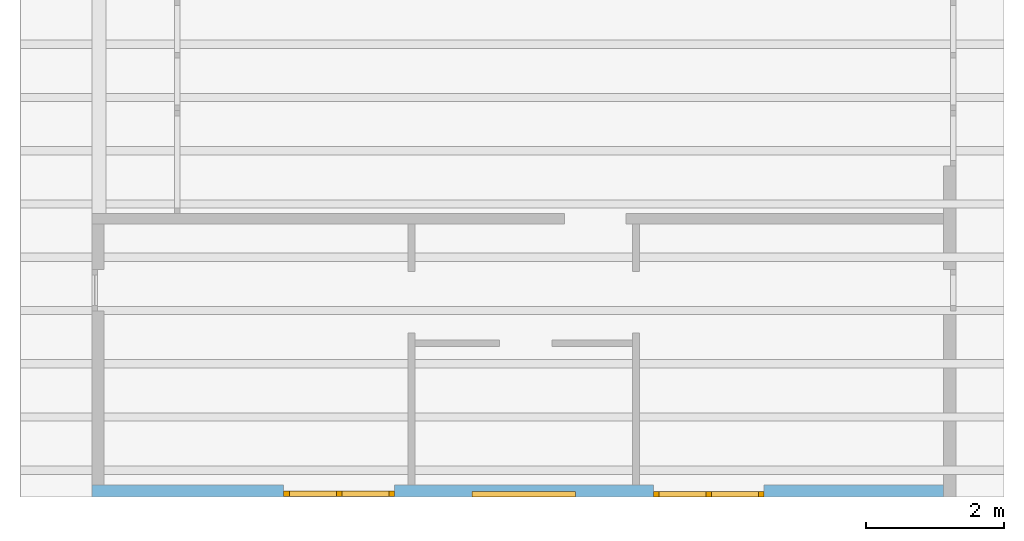
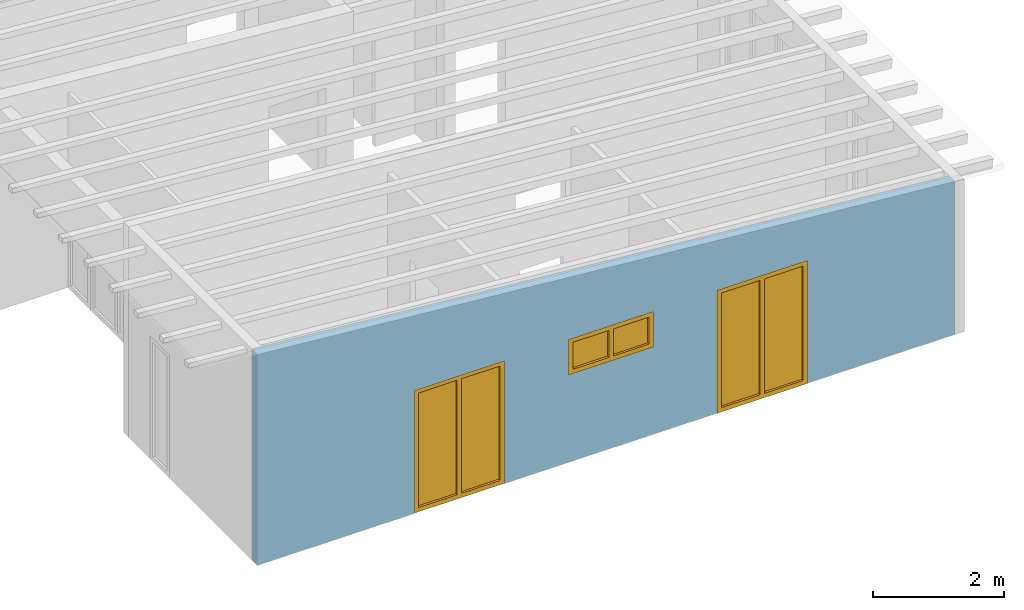
# One storey, part 5 of 13: 3 windows, 3 openings, plus 1 element that does not belong to this part.
"""IFC2X3 building model written with IfcOpenShell, lengths in millimetres."""

from ifc_helpers import new_model, entity, si_unit, converted_unit, frame, frame_2d, origin, origin_with_axes, place, context, project, spatial, rectangle, extrude, clip, halfspace, faceted_brep, material, layer, layer_set, layer_usage, element, fill, save


model = new_model("IFC2X3")

# Units and contexts
model_context = context("Model", 3, precision=1e-05, world=origin())
plan_context = context("Plan", 3, precision=1e-05, world=origin())
ifc_project = project(units=[si_unit("LENGTHUNIT", "METRE", prefix="MILLI"), converted_unit("PLANEANGLEUNIT", "DEGREE", entity("IfcPlaneAngleMeasure", 0.0174532925199433), si_unit("PLANEANGLEUNIT", "RADIAN"), dimensions=[0, 0, 0, 0, 0, 0, 0]), si_unit("AREAUNIT", "SQUARE_METRE"), si_unit("VOLUMEUNIT", "CUBIC_METRE")], contexts=[model_context, plan_context])

# Building, storey
building_placement = place(None, origin())
building = spatial("IfcBuilding", under=ifc_project, at=building_placement, CompositionType="ELEMENT")
storey_placement = place(building_placement, frame((0.0, 0.0, 4770.0), z_axis=(0.0, 0.0, 1.0), x_axis=(1.0, 0.0, 0.0)))
storey = spatial("IfcBuildingStorey", under=building, at=storey_placement, Name="Geschoss", CompositionType="ELEMENT", Elevation=4770.0)

# Wall, openings, windows
ifc_material_1 = material()
ifc_layer = layer(ifc_material_1, 175.0)
ifc_layer_set = layer_set([ifc_layer])
ifc_layer_usage = layer_usage(ifc_layer_set, "AXIS2", "POSITIVE", 0.0)
wall_placement = place(storey_placement, frame((21188.3517822139, -8691.5625, 0.0), z_axis=(0.0, 0.0, 1.0), x_axis=(1.0, 0.0, 0.0)))
wall = element("IfcWallStandardCase", 1, at=wall_placement, inside=storey, material=ifc_layer_usage, context=model_context, shape_type="Clipping", body=[
    clip(extrude(rectangle(XDim=12324.9999999553, YDim=175.0, at=frame_2d((6162.49999997765, 87.5), x_axis=(1.0, 0.0))), origin_with_axes(), (0.0, 0.0, 1.0), 3940.60829407405), halfspace(frame((12324.9999999553, 175.0, 2862.31051612095), z_axis=(-0.0871557427476578, 0.0, -0.996194698091746), x_axis=(1.0, 0.0, 0.0)), True)),
])
opening_1_placement = place(wall_placement, frame((8124.9982195274, 0.0, 0.0), z_axis=(0.0, 1.0, 0.0), x_axis=(0.0, 0.0, 1.0)))
opening_1 = element("IfcOpeningElement", 2, at=opening_1_placement, cuts=wall, ObjectType="Opening", context=model_context, shape_type="SweptSolid", body=[
    extrude(rectangle(XDim=2300.0, YDim=1600.0, at=frame_2d((1150.0, 800.0), x_axis=(1.0, 0.0))), origin_with_axes(), (0.0, 0.0, 1.0), 175.0),
])
opening_2_placement = place(wall_placement, frame((5499.99999998852, 0.0, 1635.0), z_axis=(0.0, 1.0, 0.0), x_axis=(0.0, 0.0, 1.0)))
opening_2 = element("IfcOpeningElement", 3, at=opening_2_placement, cuts=wall, ObjectType="Opening", context=model_context, shape_type="SweptSolid", body=[
    extrude(rectangle(XDim=665.0, YDim=1500.0, at=frame_2d((332.5, 750.0), x_axis=(1.0, 0.0))), origin_with_axes(), (0.0, 0.0, 1.0), 175.0),
])
opening_3_placement = place(wall_placement, frame((2775.00178047279, 0.0, 0.0), z_axis=(0.0, 1.0, 0.0), x_axis=(0.0, 0.0, 1.0)))
opening_3 = element("IfcOpeningElement", 4, at=opening_3_placement, cuts=wall, ObjectType="Opening", context=model_context, shape_type="SweptSolid", body=[
    extrude(rectangle(XDim=2300.0, YDim=1600.0, at=frame_2d((1150.0, 800.0), x_axis=(1.0, 0.0))), origin_with_axes(), (0.0, 0.0, 1.0), 175.0),
])
ifc_material_2 = material()
window_1_placement = place(opening_1_placement, frame((0.0, 0.0, 0.0), z_axis=(1.0, 0.0, 0.0), x_axis=(0.0, 1.0, 0.0)))
window_1 = element("IfcWindow", 5, at=window_1_placement, inside=storey, material=ifc_material_2, Name="m", OverallHeight=2300.0, OverallWidth=1600.0, context=model_context, shape_type="Brep", body=[
    faceted_brep([(1520.0, 4.33667546317906e-11, 0.0), (1520.0, 4.33667546317906e-11, 2300.0), (1600.0, 4.33569846691739e-11, 2300.0), (1600.0, 4.33569846691739e-11, 0.0), (1600.0, 80.0000000000434, 0.0), (1600.0, 80.0000000000434, 2300.0), (1520.0, 80.0000000000434, 2300.0), (1520.0, 80.0000000000434, 0.0), (1600.0, 4.33569846691739e-11, 0.0), (1600.0, 80.0000000000434, 0.0), (1520.0, 80.0000000000434, 0.0), (1520.0, 4.33667546317906e-11, 0.0), (1600.0, 4.33569846691739e-11, 2300.0), (1600.0, 80.0000000000434, 2300.0), (1600.0, 80.0000000000434, 0.0), (1600.0, 4.33569846691739e-11, 0.0), (1520.0, 4.33667546317906e-11, 2300.0), (1520.0, 80.0000000000434, 2300.0), (1600.0, 80.0000000000434, 2300.0), (1600.0, 4.33569846691739e-11, 2300.0), (1520.0, 4.33667546317906e-11, 0.0), (1520.0, 80.0000000000434, 0.0), (1520.0, 80.0000000000434, 2300.0), (1520.0, 4.33667546317906e-11, 2300.0)], [[[0, 1, 2, 3]], [[4, 5, 6, 7]], [[8, 9, 10, 11]], [[12, 13, 14, 15]], [[16, 17, 18, 19]], [[20, 21, 22, 23]]], orient=[[False], [False], [False], [False], [False], [False]]),
    faceted_brep([(80.0, 4.35573799251188e-11, 2300.0), (80.0, 4.35573799251188e-11, 0.0), (-7.34763812276152e-17, 4.35671498877355e-11, 0.0), (-7.34763812276152e-17, 4.35671498877355e-11, 2300.0), (9.7233744493514e-15, 80.0000000000436, 2300.0), (9.7233744493514e-15, 80.0000000000436, 0.0), (80.0, 80.0000000000436, 0.0), (80.0, 80.0000000000436, 2300.0), (-7.34763812276152e-17, 4.35671498877355e-11, 2300.0), (9.7233744493514e-15, 80.0000000000436, 2300.0), (80.0, 80.0000000000436, 2300.0), (80.0, 4.35573799251188e-11, 2300.0), (-7.34763812276152e-17, 4.35671498877355e-11, 0.0), (9.7233744493514e-15, 80.0000000000436, 0.0), (9.7233744493514e-15, 80.0000000000436, 2300.0), (-7.34763812276152e-17, 4.35671498877355e-11, 2300.0), (80.0, 4.35573799251188e-11, 0.0), (80.0, 80.0000000000436, 0.0), (9.7233744493514e-15, 80.0000000000436, 0.0), (-7.34763812276152e-17, 4.35671498877355e-11, 0.0), (80.0, 4.35573799251188e-11, 2300.0), (80.0, 80.0000000000436, 2300.0), (80.0, 80.0000000000436, 0.0), (80.0, 4.35573799251188e-11, 0.0)], [[[0, 1, 2, 3]], [[4, 5, 6, 7]], [[8, 9, 10, 11]], [[12, 13, 14, 15]], [[16, 17, 18, 19]], [[20, 21, 22, 23]]], orient=[[False], [False], [False], [False], [False], [False]]),
    faceted_brep([(1520.0, 4.3395176341221e-11, 2220.0), (80.0, 4.3571590779834e-11, 2220.0), (80.0, 4.3571590779834e-11, 2300.0), (1520.0, 4.3395176341221e-11, 2300.0), (1520.0, 80.0000000000434, 2300.0), (80.0, 80.0000000000436, 2300.0), (80.0, 80.0000000000436, 2220.0), (1520.0, 80.0000000000434, 2220.0), (1520.0, 4.3395176341221e-11, 2300.0), (1520.0, 80.0000000000434, 2300.0), (1520.0, 80.0000000000434, 2220.0), (1520.0, 4.3395176341221e-11, 2220.0), (80.0, 4.3571590779834e-11, 2300.0), (80.0, 80.0000000000436, 2300.0), (1520.0, 80.0000000000434, 2300.0), (1520.0, 4.3395176341221e-11, 2300.0), (80.0, 4.3571590779834e-11, 2220.0), (80.0, 80.0000000000436, 2220.0), (80.0, 80.0000000000436, 2300.0), (80.0, 4.3571590779834e-11, 2300.0), (1520.0, 4.3395176341221e-11, 2220.0), (1520.0, 80.0000000000434, 2220.0), (80.0, 80.0000000000436, 2220.0), (80.0, 4.3571590779834e-11, 2220.0)], [[[0, 1, 2, 3]], [[4, 5, 6, 7]], [[8, 9, 10, 11]], [[12, 13, 14, 15]], [[16, 17, 18, 19]], [[20, 21, 22, 23]]], orient=[[False], [False], [False], [False], [False], [False]]),
    faceted_brep([(80.0, 4.3571590779834e-11, 80.0), (1520.0, 4.3395176341221e-11, 80.0), (1520.0, 4.3395176341221e-11, 0.0), (80.0, 4.3571590779834e-11, 0.0), (80.0, 80.0000000000436, 0.0), (1520.0, 80.0000000000434, 0.0), (1520.0, 80.0000000000434, 80.0), (80.0, 80.0000000000436, 80.0), (80.0, 4.3571590779834e-11, 0.0), (80.0, 80.0000000000436, 0.0), (80.0, 80.0000000000436, 80.0), (80.0, 4.3571590779834e-11, 80.0), (1520.0, 4.3395176341221e-11, 0.0), (1520.0, 80.0000000000434, 0.0), (80.0, 80.0000000000436, 0.0), (80.0, 4.3571590779834e-11, 0.0), (1520.0, 4.3395176341221e-11, 80.0), (1520.0, 80.0000000000434, 80.0), (1520.0, 80.0000000000434, 0.0), (1520.0, 4.3395176341221e-11, 0.0), (80.0, 4.3571590779834e-11, 80.0), (80.0, 80.0000000000436, 80.0), (1520.0, 80.0000000000434, 80.0), (1520.0, 4.3395176341221e-11, 80.0)], [[[0, 1, 2, 3]], [[4, 5, 6, 7]], [[8, 9, 10, 11]], [[12, 13, 14, 15]], [[16, 17, 18, 19]], [[20, 21, 22, 23]]], orient=[[False], [False], [False], [False], [False], [False]]),
    faceted_brep([(760.0, 4.34883240529871e-11, 80.0), (760.0, 4.34883240529871e-11, 2220.0), (840.0, 4.34784430680679e-11, 2220.0), (840.0, 4.34784430680679e-11, 80.0), (840.0, 80.0000000000435, 80.0), (840.0, 80.0000000000435, 2220.0), (760.0, 80.0000000000435, 2220.0), (760.0, 80.0000000000435, 80.0), (840.0, 4.34784430680679e-11, 80.0), (840.0, 80.0000000000435, 80.0), (760.0, 80.0000000000435, 80.0), (760.0, 4.34883240529871e-11, 80.0), (840.0, 4.34784430680679e-11, 2220.0), (840.0, 80.0000000000435, 2220.0), (840.0, 80.0000000000435, 80.0), (840.0, 4.34784430680679e-11, 80.0), (760.0, 4.34883240529871e-11, 2220.0), (760.0, 80.0000000000435, 2220.0), (840.0, 80.0000000000435, 2220.0), (840.0, 4.34784430680679e-11, 2220.0), (760.0, 4.34883240529871e-11, 80.0), (760.0, 80.0000000000435, 80.0), (760.0, 80.0000000000435, 2220.0), (760.0, 4.34883240529871e-11, 2220.0)], [[[0, 1, 2, 3]], [[4, 5, 6, 7]], [[8, 9, 10, 11]], [[12, 13, 14, 15]], [[16, 17, 18, 19]], [[20, 21, 22, 23]]], orient=[[False], [False], [False], [False], [False], [False]]),
    faceted_brep([(80.0, 40.0000000000436, 2220.0), (760.0, 40.0000000000435, 2220.0), (760.0, 40.0000000000435, 80.0), (80.0, 40.0000000000436, 80.0), (80.0, 41.0000000000436, 2220.0), (80.0, 41.0000000000436, 80.0), (760.0, 41.0000000000435, 80.0), (760.0, 41.0000000000435, 2220.0), (80.0, 40.0000000000436, 2220.0), (80.0, 41.0000000000436, 2220.0), (760.0, 41.0000000000435, 2220.0), (760.0, 40.0000000000435, 2220.0), (760.0, 40.0000000000435, 2220.0), (760.0, 41.0000000000435, 2220.0), (760.0, 41.0000000000435, 80.0), (760.0, 40.0000000000435, 80.0), (760.0, 40.0000000000435, 80.0), (760.0, 41.0000000000435, 80.0), (80.0, 41.0000000000436, 80.0), (80.0, 40.0000000000436, 80.0), (80.0, 40.0000000000436, 80.0), (80.0, 41.0000000000436, 80.0), (80.0, 41.0000000000436, 2220.0), (80.0, 40.0000000000436, 2220.0)], [[[0, 1, 2, 3]], [[4, 5, 6, 7]], [[8, 9, 10, 11]], [[12, 13, 14, 15]], [[16, 17, 18, 19]], [[20, 21, 22, 23]]], orient=[[False], [False], [False], [False], [False], [False]]),
    faceted_brep([(1520.0, 40.0000000000434, 80.0), (840.0, 40.0000000000435, 80.0), (840.0, 40.0000000000435, 2220.0), (1520.0, 40.0000000000434, 2220.0), (1520.0, 41.0000000000434, 80.0), (1520.0, 41.0000000000434, 2220.0), (840.0, 41.0000000000435, 2220.0), (840.0, 41.0000000000435, 80.0), (1520.0, 40.0000000000434, 80.0), (1520.0, 41.0000000000434, 80.0), (840.0, 41.0000000000435, 80.0), (840.0, 40.0000000000435, 80.0), (840.0, 40.0000000000435, 80.0), (840.0, 41.0000000000435, 80.0), (840.0, 41.0000000000435, 2220.0), (840.0, 40.0000000000435, 2220.0), (840.0, 40.0000000000435, 2220.0), (840.0, 41.0000000000435, 2220.0), (1520.0, 41.0000000000434, 2220.0), (1520.0, 40.0000000000434, 2220.0), (1520.0, 40.0000000000434, 2220.0), (1520.0, 41.0000000000434, 2220.0), (1520.0, 41.0000000000434, 80.0), (1520.0, 40.0000000000434, 80.0)], [[[0, 1, 2, 3]], [[4, 5, 6, 7]], [[8, 9, 10, 11]], [[12, 13, 14, 15]], [[16, 17, 18, 19]], [[20, 21, 22, 23]]], orient=[[False], [False], [False], [False], [False], [False]]),
])
fill(opening_1, window_1)
ifc_material_3 = material()
window_2_placement = place(opening_2_placement, frame((0.0, 0.0, 0.0), z_axis=(1.0, 0.0, 0.0), x_axis=(0.0, 1.0, 0.0)))
window_2 = element("IfcWindow", 6, at=window_2_placement, inside=storey, material=ifc_material_3, Name="m", OverallHeight=665.0, OverallWidth=1500.0, context=model_context, shape_type="Brep", body=[
    faceted_brep([(80.0, 4.28888036196895e-11, 0.0), (0.0, 4.28986846046087e-11, 0.0), (0.0, 4.28986846046087e-11, 665.0), (80.0, 4.28888036196895e-11, 665.0), (0.0, 80.0000000000429, 0.0), (80.0, 80.0000000000429, 0.0), (80.0, 80.0000000000429, 665.0), (0.0, 80.0000000000429, 665.0), (0.0, 4.28986846046087e-11, 0.0), (80.0, 4.28888036196895e-11, 0.0), (80.0, 80.0000000000429, 0.0), (0.0, 80.0000000000429, 0.0), (0.0, 4.28986846046087e-11, 665.0), (0.0, 4.28986846046087e-11, 0.0), (0.0, 80.0000000000429, 0.0), (0.0, 80.0000000000429, 665.0), (80.0, 4.28888036196895e-11, 665.0), (0.0, 4.28986846046087e-11, 665.0), (0.0, 80.0000000000429, 665.0), (80.0, 80.0000000000429, 665.0), (80.0, 4.28888036196895e-11, 0.0), (80.0, 4.28888036196895e-11, 665.0), (80.0, 80.0000000000429, 665.0), (80.0, 80.0000000000429, 0.0)], [[[0, 1, 2, 3]], [[4, 5, 6, 7]], [[8, 9, 10, 11]], [[12, 13, 14, 15]], [[16, 17, 18, 19]], [[20, 21, 22, 23]]], orient=[[False], [False], [False], [False], [False], [False]]),
    faceted_brep([(1420.0, 4.26962909472195e-11, 665.0), (1500.0, 4.26865209846028e-11, 665.0), (1500.0, 4.26865209846028e-11, 0.0), (1420.0, 4.26962909472195e-11, 0.0), (1500.0, 80.0000000000427, 665.0), (1420.0, 80.0000000000427, 665.0), (1420.0, 80.0000000000427, 0.0), (1500.0, 80.0000000000427, 0.0), (1500.0, 4.26865209846028e-11, 665.0), (1420.0, 4.26962909472195e-11, 665.0), (1420.0, 80.0000000000427, 665.0), (1500.0, 80.0000000000427, 665.0), (1500.0, 4.26865209846028e-11, 0.0), (1500.0, 4.26865209846028e-11, 665.0), (1500.0, 80.0000000000427, 665.0), (1500.0, 80.0000000000427, 0.0), (1420.0, 4.26962909472195e-11, 0.0), (1500.0, 4.26865209846028e-11, 0.0), (1500.0, 80.0000000000427, 0.0), (1420.0, 80.0000000000427, 0.0), (1420.0, 4.26962909472195e-11, 665.0), (1420.0, 4.26962909472195e-11, 0.0), (1420.0, 80.0000000000427, 0.0), (1420.0, 80.0000000000427, 665.0)], [[[0, 1, 2, 3]], [[4, 5, 6, 7]], [[8, 9, 10, 11]], [[12, 13, 14, 15]], [[16, 17, 18, 19]], [[20, 21, 22, 23]]], orient=[[False], [False], [False], [False], [False], [False]]),
    faceted_brep([(1420.0, 4.26998436608983e-11, 80.0), (1420.0, 4.26998436608983e-11, 0.0), (80.0, 4.28639346239379e-11, 0.0), (80.0, 4.28639346239379e-11, 80.0), (1420.0, 80.0000000000427, 0.0), (1420.0, 80.0000000000427, 80.0), (80.0, 80.0000000000428, 80.0), (80.0, 80.0000000000428, 0.0), (1420.0, 4.26998436608983e-11, 0.0), (1420.0, 4.26998436608983e-11, 80.0), (1420.0, 80.0000000000427, 80.0), (1420.0, 80.0000000000427, 0.0), (80.0, 4.28639346239379e-11, 0.0), (1420.0, 4.26998436608983e-11, 0.0), (1420.0, 80.0000000000427, 0.0), (80.0, 80.0000000000428, 0.0), (80.0, 4.28639346239379e-11, 80.0), (80.0, 4.28639346239379e-11, 0.0), (80.0, 80.0000000000428, 0.0), (80.0, 80.0000000000428, 80.0), (1420.0, 4.26998436608983e-11, 80.0), (80.0, 4.28639346239379e-11, 80.0), (80.0, 80.0000000000428, 80.0), (1420.0, 80.0000000000427, 80.0)], [[[0, 1, 2, 3]], [[4, 5, 6, 7]], [[8, 9, 10, 11]], [[12, 13, 14, 15]], [[16, 17, 18, 19]], [[20, 21, 22, 23]]], orient=[[False], [False], [False], [False], [False], [False]]),
    faceted_brep([(80.0, 4.28639346239379e-11, 585.0), (80.0, 4.28639346239379e-11, 665.0), (1420.0, 4.26998436608983e-11, 665.0), (1420.0, 4.26998436608983e-11, 585.0), (80.0, 80.0000000000428, 665.0), (80.0, 80.0000000000428, 585.0), (1420.0, 80.0000000000427, 585.0), (1420.0, 80.0000000000427, 665.0), (80.0, 4.28639346239379e-11, 665.0), (80.0, 4.28639346239379e-11, 585.0), (80.0, 80.0000000000428, 585.0), (80.0, 80.0000000000428, 665.0), (1420.0, 4.26998436608983e-11, 665.0), (80.0, 4.28639346239379e-11, 665.0), (80.0, 80.0000000000428, 665.0), (1420.0, 80.0000000000427, 665.0), (1420.0, 4.26998436608983e-11, 585.0), (1420.0, 4.26998436608983e-11, 665.0), (1420.0, 80.0000000000427, 665.0), (1420.0, 80.0000000000427, 585.0), (80.0, 4.28639346239379e-11, 585.0), (1420.0, 4.26998436608983e-11, 585.0), (1420.0, 80.0000000000427, 585.0), (80.0, 80.0000000000428, 585.0)], [[[0, 1, 2, 3]], [[4, 5, 6, 7]], [[8, 9, 10, 11]], [[12, 13, 14, 15]], [[16, 17, 18, 19]], [[20, 21, 22, 23]]], orient=[[False], [False], [False], [False], [False], [False]]),
    faceted_brep([(790.0, 4.27876623021461e-11, 80.0), (710.0, 4.27974322647628e-11, 80.0), (710.0, 4.27974322647628e-11, 585.0), (790.0, 4.27876623021461e-11, 585.0), (710.0, 80.0000000000428, 80.0), (790.0, 80.0000000000428, 80.0), (790.0, 80.0000000000428, 585.0), (710.0, 80.0000000000428, 585.0), (710.0, 4.27974322647628e-11, 80.0), (790.0, 4.27876623021461e-11, 80.0), (790.0, 80.0000000000428, 80.0), (710.0, 80.0000000000428, 80.0), (710.0, 4.27974322647628e-11, 585.0), (710.0, 4.27974322647628e-11, 80.0), (710.0, 80.0000000000428, 80.0), (710.0, 80.0000000000428, 585.0), (790.0, 4.27876623021461e-11, 585.0), (710.0, 4.27974322647628e-11, 585.0), (710.0, 80.0000000000428, 585.0), (790.0, 80.0000000000428, 585.0), (790.0, 4.27876623021461e-11, 80.0), (790.0, 4.27876623021461e-11, 585.0), (790.0, 80.0000000000428, 585.0), (790.0, 80.0000000000428, 80.0)], [[[0, 1, 2, 3]], [[4, 5, 6, 7]], [[8, 9, 10, 11]], [[12, 13, 14, 15]], [[16, 17, 18, 19]], [[20, 21, 22, 23]]], orient=[[False], [False], [False], [False], [False], [False]]),
    faceted_brep([(1420.0, 40.0000000000427, 585.0), (1420.0, 40.0000000000427, 80.0), (790.0, 40.0000000000428, 80.0), (790.0, 40.0000000000428, 585.0), (1420.0, 41.0000000000427, 585.0), (790.0, 41.0000000000428, 585.0), (790.0, 41.0000000000428, 80.0), (1420.0, 41.0000000000427, 80.0), (1420.0, 40.0000000000427, 585.0), (1420.0, 41.0000000000427, 585.0), (1420.0, 41.0000000000427, 80.0), (1420.0, 40.0000000000427, 80.0), (1420.0, 40.0000000000427, 80.0), (1420.0, 41.0000000000427, 80.0), (790.0, 41.0000000000428, 80.0), (790.0, 40.0000000000428, 80.0), (790.0, 40.0000000000428, 80.0), (790.0, 41.0000000000428, 80.0), (790.0, 41.0000000000428, 585.0), (790.0, 40.0000000000428, 585.0), (790.0, 40.0000000000428, 585.0), (790.0, 41.0000000000428, 585.0), (1420.0, 41.0000000000427, 585.0), (1420.0, 40.0000000000427, 585.0)], [[[0, 1, 2, 3]], [[4, 5, 6, 7]], [[8, 9, 10, 11]], [[12, 13, 14, 15]], [[16, 17, 18, 19]], [[20, 21, 22, 23]]], orient=[[False], [False], [False], [False], [False], [False]]),
    faceted_brep([(710.0, 40.0000000000428, 585.0), (710.0, 40.0000000000428, 80.0), (80.0, 40.0000000000429, 80.0), (80.0, 40.0000000000429, 585.0), (710.0, 41.0000000000428, 585.0), (80.0, 41.0000000000429, 585.0), (80.0, 41.0000000000429, 80.0), (710.0, 41.0000000000428, 80.0), (710.0, 40.0000000000428, 585.0), (710.0, 41.0000000000428, 585.0), (710.0, 41.0000000000428, 80.0), (710.0, 40.0000000000428, 80.0), (710.0, 40.0000000000428, 80.0), (710.0, 41.0000000000428, 80.0), (80.0, 41.0000000000429, 80.0), (80.0, 40.0000000000429, 80.0), (80.0, 40.0000000000429, 80.0), (80.0, 41.0000000000429, 80.0), (80.0, 41.0000000000429, 585.0), (80.0, 40.0000000000429, 585.0), (80.0, 40.0000000000429, 585.0), (80.0, 41.0000000000429, 585.0), (710.0, 41.0000000000428, 585.0), (710.0, 40.0000000000428, 585.0)], [[[0, 1, 2, 3]], [[4, 5, 6, 7]], [[8, 9, 10, 11]], [[12, 13, 14, 15]], [[16, 17, 18, 19]], [[20, 21, 22, 23]]], orient=[[False], [False], [False], [False], [False], [False]]),
])
fill(opening_2, window_2)
ifc_material_4 = material()
window_3_placement = place(opening_3_placement, frame((0.0, 0.0, 0.0), z_axis=(1.0, 0.0, 0.0), x_axis=(0.0, 1.0, 0.0)))
window_3 = element("IfcWindow", 7, at=window_3_placement, inside=storey, material=ifc_material_4, Name="m", OverallHeight=2300.0, OverallWidth=1600.0, context=model_context, shape_type="Brep", body=[
    faceted_brep([(80.0, 10.000000000029, 0.0), (0.0, 10.000000000029, 0.0), (0.0, 10.000000000029, 2300.0), (80.0, 10.000000000029, 2300.0), (0.0, 90.000000000029, 0.0), (80.0, 90.000000000029, 0.0), (80.0, 90.000000000029, 2300.0), (0.0, 90.000000000029, 2300.0), (0.0, 10.000000000029, 0.0), (80.0, 10.000000000029, 0.0), (80.0, 90.000000000029, 0.0), (0.0, 90.000000000029, 0.0), (0.0, 10.000000000029, 2300.0), (0.0, 10.000000000029, 0.0), (0.0, 90.000000000029, 0.0), (0.0, 90.000000000029, 2300.0), (80.0, 10.000000000029, 2300.0), (0.0, 10.000000000029, 2300.0), (0.0, 90.000000000029, 2300.0), (80.0, 90.000000000029, 2300.0), (80.0, 10.000000000029, 0.0), (80.0, 10.000000000029, 2300.0), (80.0, 90.000000000029, 2300.0), (80.0, 90.000000000029, 0.0)], [[[0, 1, 2, 3]], [[4, 5, 6, 7]], [[8, 9, 10, 11]], [[12, 13, 14, 15]], [[16, 17, 18, 19]], [[20, 21, 22, 23]]], orient=[[False], [False], [False], [False], [False], [False]]),
    faceted_brep([(1520.0, 10.0000000000288, 2300.0), (1600.0, 10.0000000000288, 2300.0), (1600.0, 10.0000000000288, 0.0), (1520.0, 10.0000000000288, 0.0), (1600.0, 90.0000000000288, 2300.0), (1520.0, 90.0000000000288, 2300.0), (1520.0, 90.0000000000288, 0.0), (1600.0, 90.0000000000288, 0.0), (1600.0, 10.0000000000288, 2300.0), (1520.0, 10.0000000000288, 2300.0), (1520.0, 90.0000000000288, 2300.0), (1600.0, 90.0000000000288, 2300.0), (1600.0, 10.0000000000288, 0.0), (1600.0, 10.0000000000288, 2300.0), (1600.0, 90.0000000000288, 2300.0), (1600.0, 90.0000000000288, 0.0), (1520.0, 10.0000000000288, 0.0), (1600.0, 10.0000000000288, 0.0), (1600.0, 90.0000000000288, 0.0), (1520.0, 90.0000000000288, 0.0), (1520.0, 10.0000000000288, 2300.0), (1520.0, 10.0000000000288, 0.0), (1520.0, 90.0000000000288, 0.0), (1520.0, 90.0000000000288, 2300.0)], [[[0, 1, 2, 3]], [[4, 5, 6, 7]], [[8, 9, 10, 11]], [[12, 13, 14, 15]], [[16, 17, 18, 19]], [[20, 21, 22, 23]]], orient=[[False], [False], [False], [False], [False], [False]]),
    faceted_brep([(80.0, 10.000000000029, 2220.0), (80.0, 10.000000000029, 2300.0), (1520.0, 10.0000000000288, 2300.0), (1520.0, 10.0000000000288, 2220.0), (80.0, 90.000000000029, 2300.0), (80.0, 90.000000000029, 2220.0), (1520.0, 90.0000000000288, 2220.0), (1520.0, 90.0000000000288, 2300.0), (80.0, 10.000000000029, 2300.0), (80.0, 10.000000000029, 2220.0), (80.0, 90.000000000029, 2220.0), (80.0, 90.000000000029, 2300.0), (1520.0, 10.0000000000288, 2300.0), (80.0, 10.000000000029, 2300.0), (80.0, 90.000000000029, 2300.0), (1520.0, 90.0000000000288, 2300.0), (1520.0, 10.0000000000288, 2220.0), (1520.0, 10.0000000000288, 2300.0), (1520.0, 90.0000000000288, 2300.0), (1520.0, 90.0000000000288, 2220.0), (80.0, 10.000000000029, 2220.0), (1520.0, 10.0000000000288, 2220.0), (1520.0, 90.0000000000288, 2220.0), (80.0, 90.000000000029, 2220.0)], [[[0, 1, 2, 3]], [[4, 5, 6, 7]], [[8, 9, 10, 11]], [[12, 13, 14, 15]], [[16, 17, 18, 19]], [[20, 21, 22, 23]]], orient=[[False], [False], [False], [False], [False], [False]]),
    faceted_brep([(1520.0, 10.0000000000288, 80.0), (1520.0, 10.0000000000288, 0.0), (80.0, 10.000000000029, 0.0), (80.0, 10.000000000029, 80.0), (1520.0, 90.0000000000288, 0.0), (1520.0, 90.0000000000288, 80.0), (80.0, 90.000000000029, 80.0), (80.0, 90.000000000029, 0.0), (1520.0, 10.0000000000288, 0.0), (1520.0, 10.0000000000288, 80.0), (1520.0, 90.0000000000288, 80.0), (1520.0, 90.0000000000288, 0.0), (80.0, 10.000000000029, 0.0), (1520.0, 10.0000000000288, 0.0), (1520.0, 90.0000000000288, 0.0), (80.0, 90.000000000029, 0.0), (80.0, 10.000000000029, 80.0), (80.0, 10.000000000029, 0.0), (80.0, 90.000000000029, 0.0), (80.0, 90.000000000029, 80.0), (1520.0, 10.0000000000288, 80.0), (80.0, 10.000000000029, 80.0), (80.0, 90.000000000029, 80.0), (1520.0, 90.0000000000288, 80.0)], [[[0, 1, 2, 3]], [[4, 5, 6, 7]], [[8, 9, 10, 11]], [[12, 13, 14, 15]], [[16, 17, 18, 19]], [[20, 21, 22, 23]]], orient=[[False], [False], [False], [False], [False], [False]]),
    faceted_brep([(840.0, 10.0000000000289, 80.0), (760.0, 10.0000000000289, 80.0), (760.0, 10.0000000000289, 2220.0), (840.0, 10.0000000000289, 2220.0), (760.0, 90.0000000000289, 80.0), (840.0, 90.0000000000289, 80.0), (840.0, 90.0000000000289, 2220.0), (760.0, 90.0000000000289, 2220.0), (760.0, 10.0000000000289, 80.0), (840.0, 10.0000000000289, 80.0), (840.0, 90.0000000000289, 80.0), (760.0, 90.0000000000289, 80.0), (760.0, 10.0000000000289, 2220.0), (760.0, 10.0000000000289, 80.0), (760.0, 90.0000000000289, 80.0), (760.0, 90.0000000000289, 2220.0), (840.0, 10.0000000000289, 2220.0), (760.0, 10.0000000000289, 2220.0), (760.0, 90.0000000000289, 2220.0), (840.0, 90.0000000000289, 2220.0), (840.0, 10.0000000000289, 80.0), (840.0, 10.0000000000289, 2220.0), (840.0, 90.0000000000289, 2220.0), (840.0, 90.0000000000289, 80.0)], [[[0, 1, 2, 3]], [[4, 5, 6, 7]], [[8, 9, 10, 11]], [[12, 13, 14, 15]], [[16, 17, 18, 19]], [[20, 21, 22, 23]]], orient=[[False], [False], [False], [False], [False], [False]]),
    faceted_brep([(1520.0, 50.0000000000288, 2220.0), (1520.0, 50.0000000000288, 80.0), (840.0, 50.0000000000289, 80.0), (840.0, 50.0000000000289, 2220.0), (1520.0, 51.0000000000288, 2220.0), (840.0, 51.0000000000289, 2220.0), (840.0, 51.0000000000289, 80.0), (1520.0, 51.0000000000288, 80.0), (1520.0, 50.0000000000288, 2220.0), (1520.0, 51.0000000000288, 2220.0), (1520.0, 51.0000000000288, 80.0), (1520.0, 50.0000000000288, 80.0), (1520.0, 50.0000000000288, 80.0), (1520.0, 51.0000000000288, 80.0), (840.0, 51.0000000000289, 80.0), (840.0, 50.0000000000289, 80.0), (840.0, 50.0000000000289, 80.0), (840.0, 51.0000000000289, 80.0), (840.0, 51.0000000000289, 2220.0), (840.0, 50.0000000000289, 2220.0), (840.0, 50.0000000000289, 2220.0), (840.0, 51.0000000000289, 2220.0), (1520.0, 51.0000000000288, 2220.0), (1520.0, 50.0000000000288, 2220.0)], [[[0, 1, 2, 3]], [[4, 5, 6, 7]], [[8, 9, 10, 11]], [[12, 13, 14, 15]], [[16, 17, 18, 19]], [[20, 21, 22, 23]]], orient=[[False], [False], [False], [False], [False], [False]]),
    faceted_brep([(80.0, 50.000000000029, 80.0), (80.0, 50.000000000029, 2220.0), (760.0, 50.0000000000289, 2220.0), (760.0, 50.0000000000289, 80.0), (80.0, 51.000000000029, 80.0), (760.0, 51.0000000000289, 80.0), (760.0, 51.0000000000289, 2220.0), (80.0, 51.000000000029, 2220.0), (80.0, 50.000000000029, 80.0), (80.0, 51.000000000029, 80.0), (80.0, 51.000000000029, 2220.0), (80.0, 50.000000000029, 2220.0), (80.0, 50.000000000029, 2220.0), (80.0, 51.000000000029, 2220.0), (760.0, 51.0000000000289, 2220.0), (760.0, 50.0000000000289, 2220.0), (760.0, 50.0000000000289, 2220.0), (760.0, 51.0000000000289, 2220.0), (760.0, 51.0000000000289, 80.0), (760.0, 50.0000000000289, 80.0), (760.0, 50.0000000000289, 80.0), (760.0, 51.0000000000289, 80.0), (80.0, 51.000000000029, 80.0), (80.0, 50.000000000029, 80.0)], [[[0, 1, 2, 3]], [[4, 5, 6, 7]], [[8, 9, 10, 11]], [[12, 13, 14, 15]], [[16, 17, 18, 19]], [[20, 21, 22, 23]]], orient=[[False], [False], [False], [False], [False], [False]]),
])
fill(opening_3, window_3)

save(model, "model.ifc")
